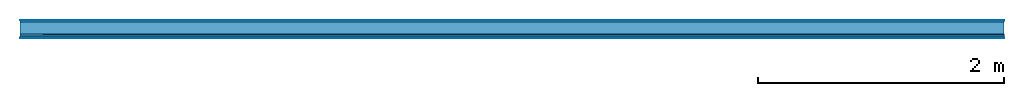
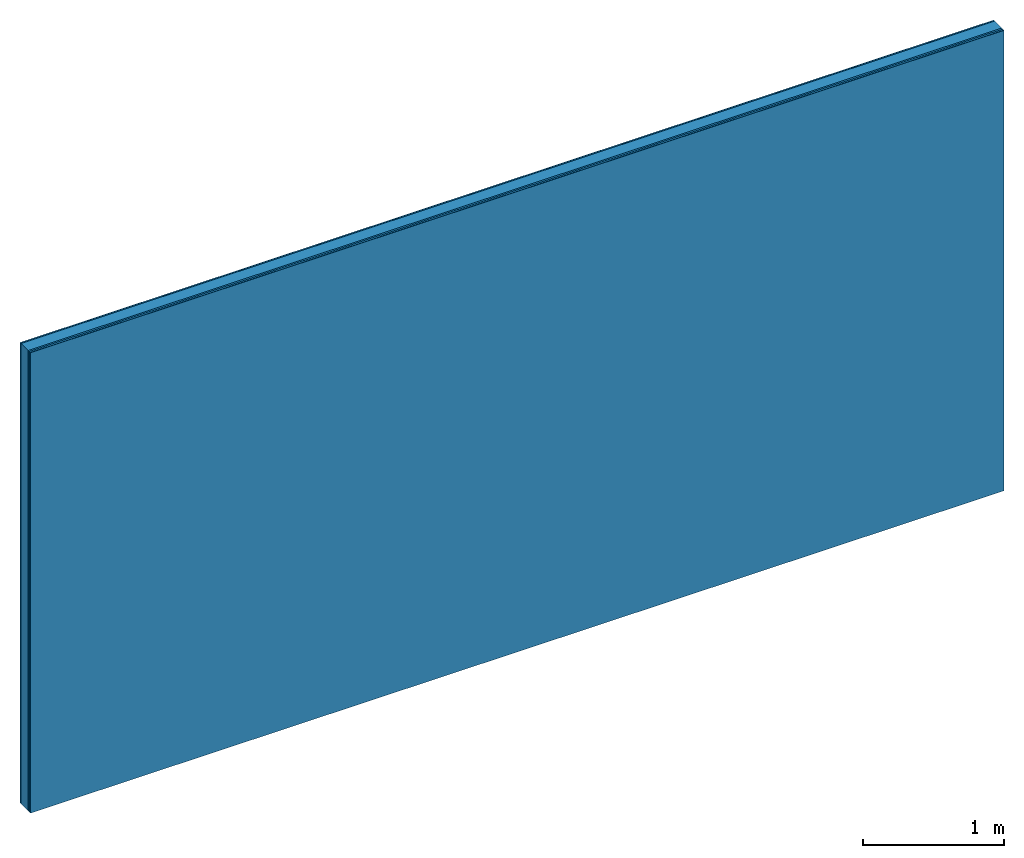
# One storey: 5 plates, 1 member, 1 element without a shape of its own.
"""IFC4 building model written with IfcOpenShell, lengths in metres."""

from ifc_helpers import new_model, si_unit, derived_unit, direction, frame, frame_2d, origin, origin_with_axes, place, context, project, spatial, rectangle, extrude, material, layer, layer_set, type_object, element, aggregate, save


model = new_model("IFC4")

# Units and contexts
plan_context = context("Plan", 3, precision=1e-05, world=origin(), true_north=direction((0.0, 1.0)))
model_context = context("Model", 3, precision=1e-05, world=origin(), true_north=direction((0.0, 1.0)))
ifc_project = project(units=[si_unit("LENGTHUNIT", "METRE"), derived_unit("SOUNDPRESSUREUNIT", [(si_unit("PRESSUREUNIT", "PASCAL", prefix="MICRO"), 0)]), si_unit("ENERGYUNIT", "JOULE", prefix="MEGA"), si_unit("MASSUNIT", "GRAM", prefix="KILO"), derived_unit("THERMALTRANSMITTANCEUNIT", [(si_unit("POWERUNIT", "WATT"), 1), (si_unit("AREAUNIT", "SQUARE_METRE"), -1), (si_unit("THERMODYNAMICTEMPERATUREUNIT", "KELVIN"), -1)]), derived_unit("AREADENSITYUNIT", [(si_unit("MASSUNIT", "GRAM", prefix="KILO"), 1), (si_unit("AREAUNIT", "SQUARE_METRE"), -1)]), derived_unit("USERDEFINED", [(si_unit("ENERGYUNIT", "JOULE", prefix="MEGA"), 1), (si_unit("AREAUNIT", "SQUARE_METRE"), -1)])], contexts=[plan_context, model_context])

# Site, building, storey
site = spatial("IfcSite", under=ifc_project)
building_placement = place(None, origin())
building = spatial("IfcBuilding", under=site, at=building_placement)
storey_placement = place(building_placement, origin())
storey = spatial("IfcBuildingStorey", under=building, at=storey_placement)

# Wall, member, plates
ifc_material_1 = material(Category="04.001")
ifc_layer_1 = layer(ifc_material_1, 0.003, Name="Surface")
ifc_material_2 = material(Name="Plasterboard type A", Category="03.008")
ifc_layer_2 = layer(ifc_material_2, 0.0125, Name="1st layer")
ifc_material_3 = material(Name="of the art")
ifc_layer_3 = layer(ifc_material_3, 0.0, Name="Bond")
ifc_layer_4 = layer(None, 0.1, Name="Support")
ifc_layer_5 = layer(ifc_material_3, 0.0, Name="Bond")
ifc_material_4 = material(Name="DFH2IR Knauf Diamant hard- plasterboard", Category="03.007")
ifc_layer_6 = layer(ifc_material_4, 0.015, Name="1st layer")
ifc_layer_7 = layer(ifc_material_4, 0.015, Name="2nd layer")
ifc_layer_8 = layer(ifc_material_1, 0.003, Name="Surface")
ifc_layer_set = layer_set([ifc_layer_1, ifc_layer_2, ifc_layer_3, ifc_layer_4, ifc_layer_5, ifc_layer_6, ifc_layer_7, ifc_layer_8])
wall_type = type_object("IfcWallType", Name="C0368", PredefinedType="NOTDEFINED", material=ifc_layer_set)
wall_placement = place(None, frame((0.0, 0.0, 0.0), z_axis=(0.0, -1.0, 0.0), x_axis=(1.0, 0.0, 0.0)))
wall = element("IfcWall", 1, at=wall_placement, inside=storey, type_object=wall_type, material=ifc_layer_set, Name="Wall #1")
ifc_material_5 = material(Name="Solid timber panel")
member_placement = place(wall_placement, origin())
member = element("IfcMember", 2, at=member_placement, material=ifc_material_5, Name="Support", context=plan_context, shape_type="SweptSolid", body=[
    extrude(rectangle(XDim=1.0, YDim=0.1, at=frame_2d((0.5, 0.05), x_axis=(1.0, 0.0))), frame((0.0, 4.0, 0.0155), z_axis=(0.0, -1.0, 0.0), x_axis=(1.0, 0.0, 0.0)), (0.0, 0.0, 1.0), 4.0),
    extrude(rectangle(XDim=1.0, YDim=0.1, at=frame_2d((0.5, 0.05), x_axis=(1.0, 0.0))), frame((1.0, 4.0, 0.0155), z_axis=(0.0, -1.0, 0.0), x_axis=(1.0, 0.0, 0.0)), (0.0, 0.0, 1.0), 4.0),
    extrude(rectangle(XDim=1.0, YDim=0.1, at=frame_2d((0.5, 0.05), x_axis=(1.0, 0.0))), frame((2.0, 4.0, 0.0155), z_axis=(0.0, -1.0, 0.0), x_axis=(1.0, 0.0, 0.0)), (0.0, 0.0, 1.0), 4.0),
    extrude(rectangle(XDim=1.0, YDim=0.1, at=frame_2d((0.5, 0.05), x_axis=(1.0, 0.0))), frame((3.0, 4.0, 0.0155), z_axis=(0.0, -1.0, 0.0), x_axis=(1.0, 0.0, 0.0)), (0.0, 0.0, 1.0), 4.0),
    extrude(rectangle(XDim=1.0, YDim=0.1, at=frame_2d((0.5, 0.05), x_axis=(1.0, 0.0))), frame((4.0, 4.0, 0.0155), z_axis=(0.0, -1.0, 0.0), x_axis=(1.0, 0.0, 0.0)), (0.0, 0.0, 1.0), 4.0),
    extrude(rectangle(XDim=1.0, YDim=0.1, at=frame_2d((0.5, 0.05), x_axis=(1.0, 0.0))), frame((5.0, 4.0, 0.0155), z_axis=(0.0, -1.0, 0.0), x_axis=(1.0, 0.0, 0.0)), (0.0, 0.0, 1.0), 4.0),
    extrude(rectangle(XDim=1.0, YDim=0.1, at=frame_2d((0.5, 0.05), x_axis=(1.0, 0.0))), frame((6.0, 4.0, 0.0155), z_axis=(0.0, -1.0, 0.0), x_axis=(1.0, 0.0, 0.0)), (0.0, 0.0, 1.0), 4.0),
    extrude(rectangle(XDim=1.0, YDim=0.1, at=frame_2d((0.5, 0.05), x_axis=(1.0, 0.0))), frame((7.0, 4.0, 0.0155), z_axis=(0.0, -1.0, 0.0), x_axis=(1.0, 0.0, 0.0)), (0.0, 0.0, 1.0), 4.0),
])
plate_1_placement = place(wall_placement, origin())
plate_1 = element("IfcPlate", 3, at=plate_1_placement, material=ifc_material_1, Name="Surface", context=plan_context, shape_type="SweptSolid", body=[
    extrude(rectangle(XDim=8.0, YDim=4.0, at=frame_2d((4.0, 2.0), x_axis=(1.0, 0.0))), origin_with_axes(), (0.0, 0.0, 1.0), 0.003),
])
plate_2_placement = place(wall_placement, origin())
plate_2 = element("IfcPlate", 4, at=plate_2_placement, material=ifc_material_2, Name="1st layer", context=plan_context, shape_type="SweptSolid", body=[
    extrude(rectangle(XDim=8.0, YDim=4.0, at=frame_2d((4.0, 2.0), x_axis=(1.0, 0.0))), frame((0.0, 0.0, 0.003), z_axis=(0.0, 0.0, 1.0), x_axis=(1.0, 0.0, 0.0)), (0.0, 0.0, 1.0), 0.0125),
])
plate_3_placement = place(wall_placement, origin())
plate_3 = element("IfcPlate", 5, at=plate_3_placement, material=ifc_material_4, Name="1st layer", context=plan_context, shape_type="SweptSolid", body=[
    extrude(rectangle(XDim=8.0, YDim=4.0, at=frame_2d((4.0, 2.0), x_axis=(1.0, 0.0))), frame((0.0, 0.0, 0.1155), z_axis=(0.0, 0.0, 1.0), x_axis=(1.0, 0.0, 0.0)), (0.0, 0.0, 1.0), 0.015),
])
plate_4_placement = place(wall_placement, origin())
plate_4 = element("IfcPlate", 6, at=plate_4_placement, material=ifc_material_4, Name="2nd layer", context=plan_context, shape_type="SweptSolid", body=[
    extrude(rectangle(XDim=8.0, YDim=4.0, at=frame_2d((4.0, 2.0), x_axis=(1.0, 0.0))), frame((0.0, 0.0, 0.1305), z_axis=(0.0, 0.0, 1.0), x_axis=(1.0, 0.0, 0.0)), (0.0, 0.0, 1.0), 0.015),
])
plate_5_placement = place(wall_placement, origin())
plate_5 = element("IfcPlate", 7, at=plate_5_placement, material=ifc_material_1, Name="Surface", context=plan_context, shape_type="SweptSolid", body=[
    extrude(rectangle(XDim=8.0, YDim=4.0, at=frame_2d((4.0, 2.0), x_axis=(1.0, 0.0))), frame((0.0, 0.0, 0.1455), z_axis=(0.0, 0.0, 1.0), x_axis=(1.0, 0.0, 0.0)), (0.0, 0.0, 1.0), 0.003),
])
aggregate(wall, [plate_1, plate_2, member, plate_3, plate_4, plate_5])

save(model, "model.ifc")
